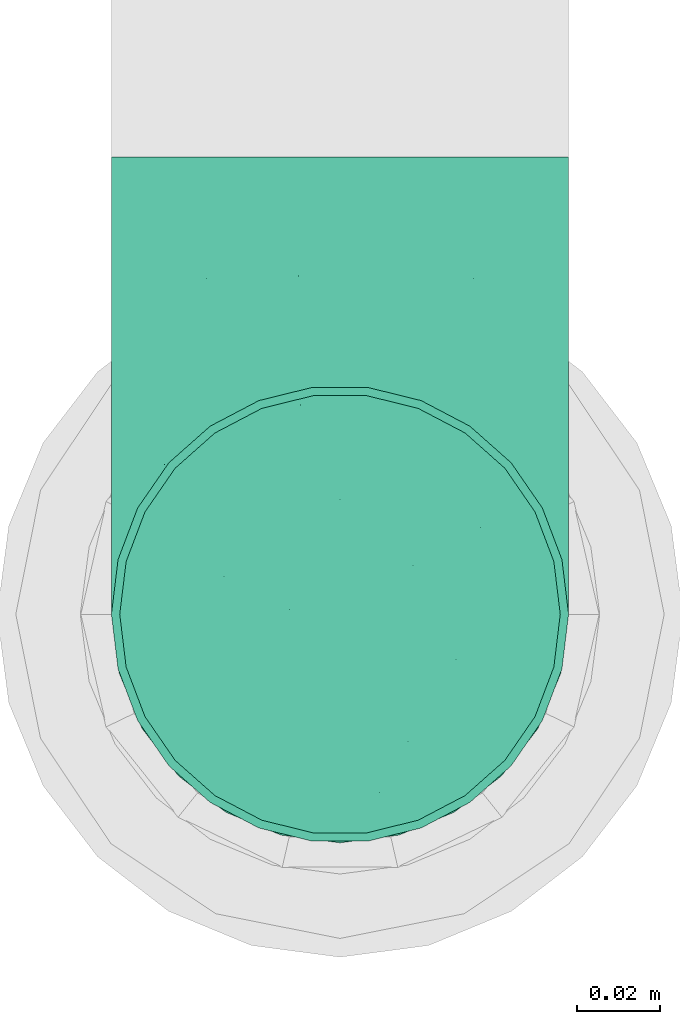
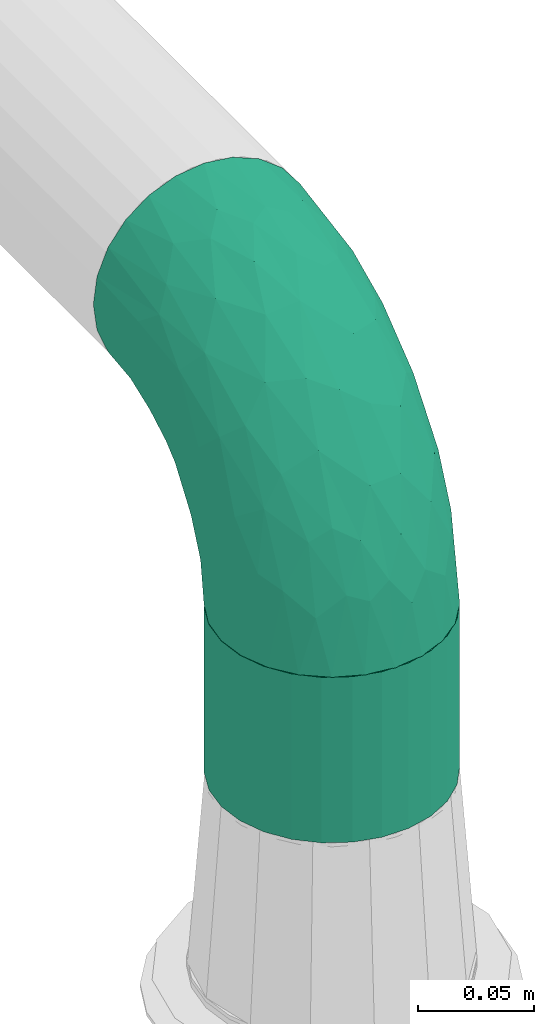
# One storey, part 107 of 115: 1 flow fitting, 1 flow segment.
"""IFC2X3 building model written with IfcOpenShell, lengths in millimetres."""

from ifc_helpers import new_model, entity, si_unit, converted_unit, derived_unit, direction, frame, origin_with_axes, origin_2d_with_axis, place, context, subcontext, project, spatial, hollow_circle, extrude, open_shell, surface_model, source, transform, mapped, material, layer, layer_set, layer_usage, type_object, element, save


model = new_model("IFC2X3")

# Units and contexts
model_context = context("Model", 3, precision=1e-05, world=origin_with_axes(), true_north=direction((0.0, 1.0)))
body_context = subcontext(model_context, "Body", "Model", "MODEL_VIEW")
ifc_project = project(units=[si_unit("AREAUNIT", "SQUARE_METRE"), si_unit("VOLUMEUNIT", "CUBIC_METRE", prefix="DECI"), si_unit("TIMEUNIT", "SECOND"), si_unit("THERMODYNAMICTEMPERATUREUNIT", "DEGREE_CELSIUS"), si_unit("PRESSUREUNIT", "PASCAL"), si_unit("MASSUNIT", "GRAM", prefix="KILO"), si_unit("LENGTHUNIT", "METRE", prefix="MILLI"), si_unit("POWERUNIT", "WATT"), si_unit("ELECTRICCURRENTUNIT", "AMPERE"), si_unit("ELECTRICVOLTAGEUNIT", "VOLT"), derived_unit("VOLUMETRICFLOWRATEUNIT", [(si_unit("VOLUMEUNIT", "CUBIC_METRE", prefix="DECI"), 1), (si_unit("TIMEUNIT", "SECOND"), -1)]), derived_unit("LINEARVELOCITYUNIT", [(si_unit("LENGTHUNIT", "METRE"), 1), (si_unit("TIMEUNIT", "SECOND"), -1)]), derived_unit("MASSDENSITYUNIT", [(si_unit("MASSUNIT", "GRAM", prefix="KILO"), 1), (si_unit("VOLUMEUNIT", "CUBIC_METRE"), -1)]), converted_unit("PLANEANGLEUNIT", "DEGREE", entity("IfcRatioMeasure", 0.01745), si_unit("PLANEANGLEUNIT", "RADIAN"), dimensions=[0, 0, 0, 0, 0, 0, 0])], contexts=[model_context])

# Site, building, storey
site_placement = place(None, origin_with_axes())
site = spatial("IfcSite", under=ifc_project, at=site_placement, CompositionType="ELEMENT")
building_placement = place(site_placement, origin_with_axes())
building = spatial("IfcBuilding", under=site, at=building_placement, Name="mc-building", CompositionType="ELEMENT")
storey_placement = place(building_placement, frame((0.0, 0.0, 2950.0), z_axis=(0.0, 0.0, 1.0), x_axis=(1.0, 0.0, 0.0)))
storey = spatial("IfcBuildingStorey", under=building, at=storey_placement, Name="2. Korrus", CompositionType="ELEMENT", Elevation=2950.0)

# Flow fitting
duct_fitting_type = type_object("IfcDuctFittingType", Name="BU", PredefinedType="BEND")
shared_shape_1 = source(origin_with_axes(), body_context, "Body", "SurfaceModel", [
    surface_model("IfcShellBasedSurfaceModel", [(-110.0, 0.0, -55.0), (-110.0, -14.23505, -53.12592), (-110.0, 14.23505, -53.12592), (-110.0, 53.12592, 14.23505), (-110.0, 27.5, -47.63139), (-110.0, 38.89087, -38.89087), (-110.0, -55.0, 0.0), (-110.0, -53.12592, 14.23505), (-110.0, -38.89087, -38.89087), (-110.0, -27.5, -47.63139), (-110.0, -53.12592, -14.23505), (-110.0, -47.63139, -27.5), (-110.0, -14.23505, 53.12592), (-110.0, 14.23505, 53.12592), (-110.0, 27.5, 47.63139), (-110.0, -47.63139, 27.5), (-110.0, -38.89087, 38.89087), (-110.0, -27.5, 47.63139), (-110.0, 0.0, 55.0), (-110.0, 55.0, 0.0), (-110.0, 53.12592, -14.23505), (-110.0, 47.63139, -27.5), (-110.0, 47.63139, 27.5), (-110.0, 38.89087, 38.89087), (-14.23505, 110.0, -53.12592), (-55.0, 110.0, 0.0), (0.0, 110.0, -55.0), (-27.5, 110.0, -47.63139), (-38.89087, 110.0, -38.89087), (-47.63139, 110.0, -27.5), (38.89087, 110.0, -38.89087), (53.12592, 110.0, 14.23505), (27.5, 110.0, -47.63139), (14.23505, 110.0, -53.12592), (47.63139, 110.0, -27.5), (53.12592, 110.0, -14.23505), (55.0, 110.0, 0.0), (-53.12592, 110.0, -14.23505), (-53.12592, 110.0, 14.23505), (-47.63139, 110.0, 27.5), (-38.89087, 110.0, 38.89087), (-27.5, 110.0, 47.63139), (0.0, 110.0, 55.0), (-14.23505, 110.0, 53.12592), (38.89087, 110.0, 38.89087), (47.63139, 110.0, 27.5), (27.5, 110.0, 47.63139), (14.23505, 110.0, 53.12592), (-64.21732, 48.68956, 43.63444), (-76.6405, 38.18013, 45.55988), (-60.44912, 32.56953, 51.94617), (-76.00813, 5.38378, 55.0), (-90.15553, 11.94394, 54.09138), (-78.5998, 26.77405, 50.81338), (-70.18771, 18.55163, 54.03432), (-75.55424, 54.2118, 32.41257), (-93.27622, 45.77614, 33.48188), (-96.12334, 22.13664, 50.81337), (-21.00813, 45.34362, 55.0), (-18.36258, 70.48427, 54.04484), (-32.04182, 59.64019, 52.24446), (-63.88653, 74.77858, 17.99134), (-74.66383, 63.08407, 19.92123), (-63.60674, 66.07878, 29.97482), (-99.597, 52.72185, 18.52927), (-93.11138, 56.59448, 10.50359), (-98.21577, 57.34403, 0.0), (-53.42855, 92.60092, 21.04759), (-88.54852, 54.8376, 21.04759), (-11.86161, 90.23965, 54.10313), (-5.38378, 76.00813, 55.0), (-57.34403, 98.21577, 0.0), (-56.64619, 93.12774, 10.22088), (-45.34362, 21.00813, 55.0), (-44.60838, 44.60838, 52.13415), (-92.68484, 35.46673, 43.63443), (-22.25266, 95.40765, 50.81337), (-35.97783, 90.61597, 43.63443), (-43.70931, 69.58671, 44.47149), (-27.23711, 77.39884, 50.81337), (-57.2828, 79.3123, 24.9774), (-58.67786, 84.31125, 16.04456), (-82.93277, 60.36161, 12.91784), (-49.88337, 54.51816, 47.224), (-74.57753, 66.83759, 9.55742), (-45.35812, 94.97281, 33.48188), (-59.18663, 88.95241, 0.0), (-51.517, 78.6292, 33.48188), (-65.14788, 80.03077, 0.0), (-56.45322, 62.06476, 39.63545), (-88.95241, 59.18663, 0.0), (-71.10913, 71.10913, 0.0), (-80.03077, 65.14788, 0.0), (-94.9309, 45.36788, -33.48188), (-93.11358, 56.60141, -10.46614), (-99.64997, 52.79499, -18.30015), (-90.20425, 36.08686, -43.63443), (-79.99933, 46.56772, -37.92748), (-76.00813, 5.38378, -55.0), (-72.75364, 19.68651, -53.60527), (-45.34362, 21.00813, -55.0), (-21.91957, 65.12078, -53.85897), (-5.38378, 76.00813, -55.0), (-21.00813, 45.34362, -55.0), (-35.41876, 92.89265, -43.63443), (-91.10309, 11.02766, -54.21832), (-45.77614, 93.27622, -33.48188), (-90.50474, 23.21022, -50.81337), (-70.92854, 33.31794, -49.51754), (-78.52933, 63.35627, -11.73997), (-24.91508, 84.05606, -50.81337), (-88.78941, 54.74452, -21.04759), (-69.59921, 57.34866, -33.48187), (-73.36422, 62.46673, -22.94182), (-63.49062, 67.59111, -28.46929), (-56.59448, 93.11138, -10.50359), (-54.8376, 88.54852, -21.04759), (-54.10679, 75.85581, -32.31867), (-57.75956, 31.09612, -52.80882), (-52.72185, 99.597, -18.52927), (-12.62913, 89.46304, -53.99097), (-34.46825, 66.46123, -50.04329), (-43.9837, 43.9837, -52.42279), (-65.78527, 72.58348, -17.68796), (-70.34468, 43.65295, -44.21951), (-57.47001, 51.99467, -44.91465), (-60.72547, 82.29174, -12.88567), (-42.34915, 74.24548, -43.63444), (-57.25194, 63.5016, -38.08211), (-80.95344, 53.56991, -29.32027), (-52.32891, 4.55257, -54.0482), (32.52942, 47.13398, -30.48571), (14.88266, 20.92917, -33.7947), (14.95561, 36.05775, -42.26543), (30.24048, 70.09027, -41.7461), (19.3559, 65.35825, -48.00507), (-70.35075, -46.44478, -19.5952), (-47.13398, -32.52942, -30.48571), (-28.49299, -30.5778, -16.4009), (-4.55257, 52.32891, -54.0482), (-22.4954, 22.4954, -53.25347), (-75.47368, -11.22546, -52.60718), (-81.32209, -51.5606, -9.98467), (-80.81763, -41.84862, -32.14655), (-70.09027, -30.24048, -41.7461), (-36.05774, -14.95561, -42.26543), (-9.15831, -10.852, -27.8997), (-65.35825, -19.3559, -48.00507), (11.22546, 75.47368, -52.60718), (3.94376, 43.9333, -50.53315), (-13.39742, 13.39743, -48.13058), (-43.9333, -3.94376, -50.53315), (49.37776, 67.29486, 0.0), (41.8609, 47.82256, -9.92641), (50.20582, 74.51695, -9.9731), (18.93131, 11.7156, -17.56239), (-27.5, -32.89419, 0.0), (-1.23348, -12.25375, -12.18106), (41.84862, 80.81763, -32.14655), (35.70604, 41.31408, -20.38235), (46.44478, 70.35075, -19.5952), (32.89419, 27.5, 0.0), (6.67262, -6.67262, 0.0), (-67.29486, -49.37776, 0.0), (-50.36265, -42.95545, -9.51562), (-5.47251, 5.47251, -39.92906), (-70.35075, -46.44478, 19.5952), (-74.51695, -50.20582, 9.9731), (-41.31407, -35.70604, 20.38235), (-47.13398, -32.52942, 30.48571), (-80.81763, -41.84862, 32.14655), (-4.55257, 52.32891, 54.0482), (11.22546, 75.47368, 52.60718), (-43.9333, -3.94376, 50.53315), (-65.35825, -19.3559, 48.00507), (-36.05774, -14.95561, 42.26543), (-70.09027, -30.24048, 41.7461), (-11.7156, -18.93131, 17.56239), (30.5778, 28.49299, 16.4009), (12.25375, 1.23348, 12.18106), (51.5606, 81.32209, 9.98467), (42.95545, 50.36265, 9.51562), (-75.47368, -11.22546, 52.60718), (-52.32891, 4.55257, 54.0482), (3.94376, 43.9333, 50.53315), (-22.4954, 22.4954, 53.25347), (-13.39742, 13.39743, 48.13058), (10.852, 9.15831, 27.8997), (-20.92916, -14.88266, 33.79469), (-47.82256, -41.8609, 9.92641), (32.52942, 47.13398, 30.48571), (46.44478, 70.35075, 19.5952), (41.84862, 80.81763, 32.14655), (30.24048, 70.09027, 41.7461), (19.3559, 65.35825, 48.00507), (14.95561, 36.05775, 42.26543), (-5.47251, 5.47251, 39.92906)], [open_shell([[[0, 1, 2]], [[2, 3, 4]], [[4, 3, 5]], [[2, 6, 7]], [[8, 6, 9]], [[1, 9, 6]], [[10, 6, 11]], [[8, 11, 6]], [[6, 2, 1]], [[12, 13, 14]], [[15, 2, 7]], [[16, 17, 2]], [[2, 17, 12]], [[12, 18, 13]], [[19, 20, 3]], [[5, 3, 21]], [[20, 21, 3]], [[22, 3, 2]], [[23, 22, 2]], [[12, 14, 2]], [[2, 14, 23]], [[15, 16, 2]], [[24, 25, 26]], [[27, 25, 24]], [[25, 28, 29]], [[28, 25, 27]], [[30, 26, 31]], [[26, 30, 32]], [[32, 33, 26]], [[34, 31, 35]], [[31, 34, 30]], [[35, 31, 36]], [[29, 37, 25]], [[38, 39, 26]], [[39, 40, 26]], [[41, 42, 40]], [[42, 26, 40]], [[42, 41, 43]], [[26, 44, 45]], [[31, 26, 45]], [[26, 46, 44]], [[47, 46, 26]], [[42, 47, 26]], [[25, 38, 26]], [[48, 49, 50]], [[18, 51, 52]], [[53, 54, 50]], [[55, 56, 49]], [[56, 22, 23]], [[13, 57, 14]], [[58, 59, 60]], [[61, 62, 63]], [[3, 64, 65]], [[53, 52, 54]], [[3, 65, 66]], [[67, 39, 38]], [[56, 68, 64]], [[65, 64, 68]], [[69, 59, 70]], [[38, 71, 72]], [[73, 58, 74]], [[75, 49, 56]], [[76, 69, 43]], [[53, 57, 52]], [[77, 78, 79]], [[41, 76, 43]], [[43, 69, 42]], [[55, 68, 56]], [[23, 14, 75]], [[76, 77, 79]], [[80, 67, 81]], [[62, 82, 68]], [[60, 78, 83]], [[62, 84, 82]], [[85, 77, 40]], [[81, 67, 72]], [[86, 72, 71]], [[87, 85, 67]], [[61, 81, 88]], [[77, 41, 40]], [[78, 77, 87]], [[23, 75, 56]], [[83, 89, 48]], [[85, 40, 39]], [[62, 68, 55]], [[89, 87, 63]], [[83, 48, 50]], [[57, 75, 14]], [[49, 75, 53]], [[67, 85, 39]], [[87, 77, 85]], [[63, 62, 55]], [[89, 55, 48]], [[80, 63, 87]], [[66, 65, 90]], [[66, 19, 3]], [[84, 91, 92]], [[92, 90, 82]], [[65, 82, 90]], [[61, 84, 62]], [[92, 82, 84]], [[68, 82, 65]], [[3, 22, 64]], [[56, 64, 22]], [[38, 25, 71]], [[81, 72, 86]], [[38, 72, 67]], [[91, 61, 88]], [[80, 81, 61]], [[63, 80, 61]], [[67, 80, 87]], [[77, 76, 41]], [[79, 59, 69]], [[79, 69, 76]], [[42, 69, 70]], [[60, 59, 79]], [[58, 70, 59]], [[78, 60, 79]], [[58, 60, 74]], [[52, 57, 13]], [[75, 57, 53]], [[18, 52, 13]], [[52, 51, 54]], [[51, 73, 54]], [[50, 73, 74]], [[73, 50, 54]], [[50, 74, 83]], [[60, 83, 74]], [[89, 83, 78]], [[87, 89, 78]], [[55, 89, 63]], [[50, 49, 53]], [[55, 49, 48]], [[81, 86, 88]], [[91, 84, 61]], [[5, 21, 93]], [[90, 94, 66]], [[20, 94, 95]], [[96, 93, 97]], [[98, 99, 100]], [[96, 4, 5]], [[101, 102, 103]], [[28, 27, 104]], [[2, 105, 0]], [[104, 106, 28]], [[99, 105, 107]], [[108, 107, 96]], [[90, 109, 94]], [[107, 2, 4]], [[20, 66, 94]], [[27, 24, 110]], [[109, 111, 94]], [[112, 113, 114]], [[37, 115, 71]], [[116, 106, 117]], [[99, 118, 100]], [[116, 115, 119]], [[37, 119, 115]], [[24, 120, 110]], [[121, 110, 101]], [[119, 106, 116]], [[101, 110, 120]], [[122, 103, 100]], [[117, 123, 116]], [[124, 125, 108]], [[115, 116, 126]], [[106, 29, 28]], [[26, 102, 120]], [[127, 104, 110]], [[97, 124, 96]], [[125, 122, 118]], [[128, 127, 125]], [[96, 5, 93]], [[115, 126, 86]], [[117, 106, 127]], [[111, 113, 129]], [[95, 93, 21]], [[97, 129, 112]], [[110, 104, 27]], [[106, 104, 127]], [[96, 107, 4]], [[99, 107, 108]], [[99, 108, 118]], [[105, 99, 98]], [[112, 114, 128]], [[121, 125, 127]], [[20, 19, 66]], [[109, 90, 92]], [[94, 111, 95]], [[91, 123, 109]], [[129, 113, 112]], [[93, 95, 111]], [[21, 20, 95]], [[71, 115, 86]], [[71, 25, 37]], [[123, 91, 88]], [[126, 116, 123]], [[123, 88, 126]], [[86, 126, 88]], [[37, 29, 119]], [[106, 119, 29]], [[129, 93, 111]], [[124, 112, 125]], [[0, 105, 98]], [[107, 105, 2]], [[125, 118, 108]], [[100, 118, 122]], [[93, 129, 97]], [[113, 111, 109]], [[109, 123, 113]], [[114, 123, 117]], [[123, 114, 113]], [[128, 114, 117]], [[127, 128, 117]], [[112, 128, 125]], [[103, 122, 101]], [[110, 121, 127]], [[101, 122, 121]], [[125, 121, 122]], [[26, 120, 24]], [[101, 120, 102]], [[96, 124, 108]], [[92, 91, 109]], [[112, 124, 97]], [[100, 130, 98]], [[131, 132, 133]], [[32, 134, 135]], [[136, 137, 138]], [[139, 140, 103]], [[98, 141, 0]], [[142, 10, 136]], [[143, 144, 137]], [[6, 10, 142]], [[137, 145, 146]], [[144, 147, 145]], [[143, 136, 11]], [[11, 136, 10]], [[8, 143, 11]], [[148, 149, 139]], [[8, 9, 144]], [[9, 1, 147]], [[130, 141, 98]], [[103, 140, 100]], [[148, 135, 149]], [[150, 151, 140]], [[152, 153, 154]], [[130, 140, 151]], [[148, 26, 33]], [[147, 1, 141]], [[155, 146, 132]], [[156, 138, 157]], [[134, 30, 158]], [[150, 140, 149]], [[158, 30, 34]], [[30, 134, 32]], [[153, 159, 160]], [[131, 160, 159]], [[144, 145, 137]], [[36, 152, 154]], [[146, 138, 137]], [[155, 161, 162]], [[158, 160, 131]], [[133, 149, 135]], [[156, 163, 164]], [[163, 142, 164]], [[139, 103, 102]], [[153, 152, 161]], [[34, 35, 160]], [[162, 157, 155]], [[132, 165, 133]], [[157, 146, 155]], [[140, 130, 100]], [[141, 130, 151]], [[141, 151, 147]], [[141, 1, 0]], [[102, 26, 148]], [[140, 139, 149]], [[102, 148, 139]], [[135, 33, 32]], [[151, 150, 145]], [[9, 147, 144]], [[151, 145, 147]], [[145, 165, 146]], [[135, 148, 33]], [[133, 135, 134]], [[131, 133, 134]], [[133, 165, 150]], [[133, 150, 149]], [[145, 150, 165]], [[132, 131, 159]], [[146, 165, 132]], [[160, 158, 34]], [[134, 158, 131]], [[144, 143, 8]], [[136, 143, 137]], [[155, 153, 161]], [[154, 153, 160]], [[153, 155, 159]], [[132, 159, 155]], [[160, 35, 154]], [[36, 154, 35]], [[164, 136, 138]], [[6, 142, 163]], [[136, 164, 142]], [[156, 164, 138]], [[156, 157, 162]], [[146, 157, 138]], [[15, 7, 166]], [[6, 163, 167]], [[168, 169, 166]], [[166, 169, 170]], [[171, 172, 70]], [[173, 174, 175]], [[17, 176, 174]], [[177, 156, 162]], [[176, 16, 170]], [[170, 16, 15]], [[161, 178, 179]], [[152, 180, 181]], [[182, 173, 183]], [[18, 12, 182]], [[184, 185, 186]], [[183, 185, 73]], [[183, 73, 51]], [[177, 187, 188]], [[189, 168, 166]], [[187, 178, 190]], [[16, 176, 17]], [[161, 152, 181]], [[45, 191, 31]], [[45, 44, 192]], [[192, 191, 45]], [[180, 36, 31]], [[193, 194, 195]], [[46, 47, 194]], [[193, 195, 190]], [[193, 44, 46]], [[172, 42, 70]], [[185, 58, 73]], [[189, 163, 156]], [[163, 189, 167]], [[70, 58, 171]], [[184, 171, 185]], [[169, 188, 175]], [[180, 31, 191]], [[192, 193, 190]], [[191, 190, 178]], [[182, 174, 173]], [[194, 47, 172]], [[190, 195, 187]], [[186, 185, 173]], [[162, 179, 177]], [[188, 196, 175]], [[179, 187, 177]], [[185, 171, 58]], [[172, 171, 184]], [[172, 184, 194]], [[172, 47, 42]], [[51, 18, 182]], [[185, 183, 173]], [[51, 182, 183]], [[174, 12, 17]], [[184, 186, 195]], [[46, 194, 193]], [[184, 195, 194]], [[195, 196, 187]], [[174, 182, 12]], [[175, 174, 176]], [[169, 175, 176]], [[175, 196, 186]], [[175, 186, 173]], [[195, 186, 196]], [[188, 169, 168]], [[187, 196, 188]], [[166, 170, 15]], [[176, 170, 169]], [[193, 192, 44]], [[191, 192, 190]], [[177, 189, 156]], [[167, 189, 166]], [[189, 177, 168]], [[188, 168, 177]], [[166, 7, 167]], [[6, 167, 7]], [[181, 191, 178]], [[36, 180, 152]], [[191, 181, 180]], [[161, 181, 178]], [[161, 179, 162]], [[187, 179, 178]]])]),
])
flow_fitting_placement = place(storey_placement, frame((37769.98441, 6519.73852, -350.0), z_axis=(1.0, 0.0, 0.0), x_axis=(0.0, -1.0, 0.0)))
element("IfcFlowFitting", 1, at=flow_fitting_placement, inside=storey, type_object=duct_fitting_type, Name="BU", context=body_context, shape_type="MappedRepresentation", body=[
    mapped(shared_shape_1, transform((0.0, 0.0, 0.0), scale=1.0)),
])

# Flow segment
ifc_material = material(Name="FZ1")
ifc_layer = layer(ifc_material, 0.0)
ifc_layer_set = layer_set([ifc_layer], Name="FZ1")
ifc_layer_usage = layer_usage(ifc_layer_set, "AXIS1", "POSITIVE", 0.0)
duct_segment_type = type_object("IfcDuctSegmentType", PredefinedType="RIGIDSEGMENT")
shared_shape_2 = source(origin_with_axes(), body_context, "Body", "SweptSolid", [
    extrude(hollow_circle(Radius=55.0, WallThickness=2.0, at=origin_2d_with_axis()), frame((0.0, 0.0, 0.0), z_axis=(1.0, 0.0, 0.0), x_axis=(0.0, 1.0, 0.0)), (0.0, 0.0, 1.0), 86.9),
])
flow_segment_placement = place(storey_placement, frame((37769.98441, 6519.73852, -460.0), z_axis=(0.0, -1.0, 0.0), x_axis=(0.0, 0.0, -1.0)))
element("IfcFlowSegment", 2, at=flow_segment_placement, inside=storey, type_object=duct_segment_type, material=ifc_layer_usage, context=body_context, shape_type="MappedRepresentation", body=[
    mapped(shared_shape_2, transform((0.0, 0.0, 0.0), scale=1.0)),
])

save(model, "model.ifc")
